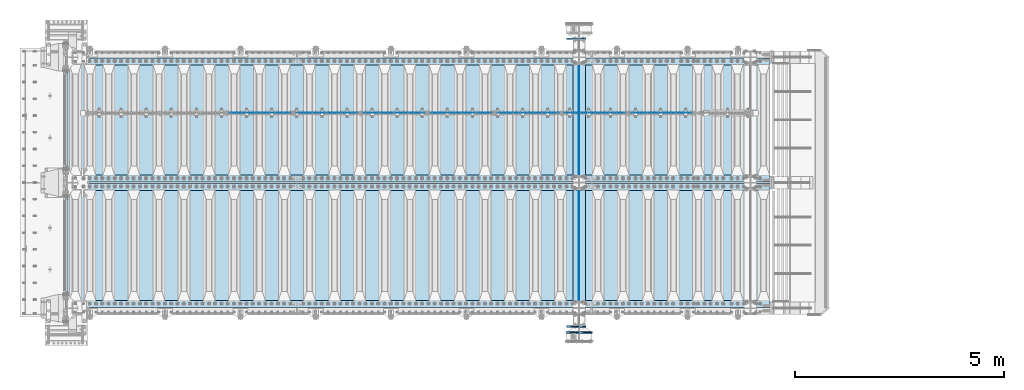
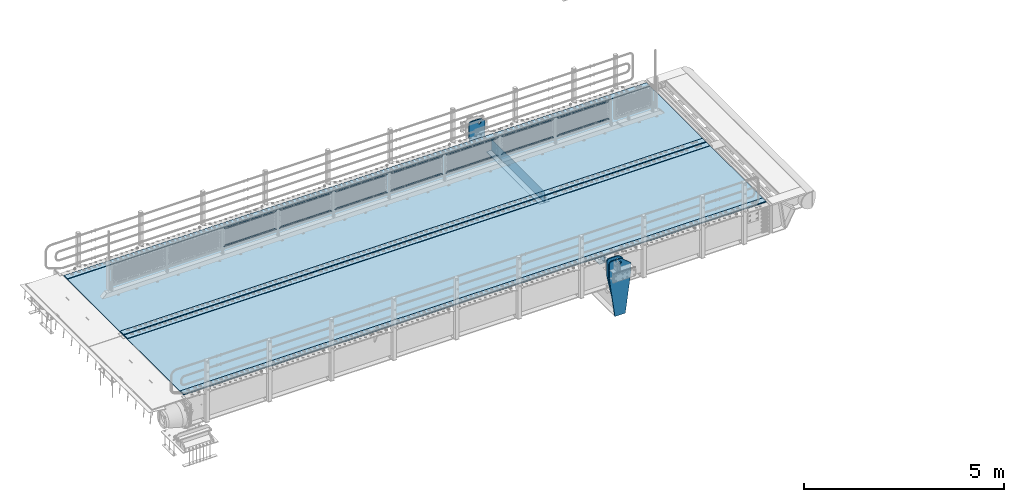
# One storey, part 164 of 208: 27 plates.
"""IFC2X3 building model written with IfcOpenShell, lengths in millimetres."""

from ifc_helpers import new_model, si_unit, frame, origin_with_axes, place, context, subcontext, project, spatial, faceted_brep, material, type_object, element, save


model = new_model("IFC2X3")

# Units and contexts
model_context = context("Model", 3, precision=1e-05, world=origin_with_axes())
body_context = subcontext(model_context, "Body", "Model", "MODEL_VIEW")
ifc_project = project(units=[si_unit("LENGTHUNIT", "METRE", prefix="MILLI"), si_unit("AREAUNIT", "SQUARE_METRE"), si_unit("VOLUMEUNIT", "CUBIC_METRE"), si_unit("MASSUNIT", "GRAM", prefix="KILO"), si_unit("TIMEUNIT", "SECOND"), si_unit("PLANEANGLEUNIT", "RADIAN"), si_unit("SOLIDANGLEUNIT", "STERADIAN"), si_unit("THERMODYNAMICTEMPERATUREUNIT", "DEGREE_CELSIUS"), si_unit("LUMINOUSINTENSITYUNIT", "LUMEN")], contexts=[model_context])

# Site, building, storey
site_placement = place(None, origin_with_axes())
site = spatial("IfcSite", under=ifc_project, at=site_placement, CompositionType="ELEMENT")
building_placement = place(site_placement, origin_with_axes())
building = spatial("IfcBuilding", under=site, at=building_placement, Name="Standard", CompositionType="ELEMENT")
storey_placement = place(building_placement, origin_with_axes())
storey = spatial("IfcBuildingStorey", under=building, at=storey_placement, Name="Undefined", CompositionType="ELEMENT", Elevation=0.0)

# Plates
ifc_material_1 = material(Name="STEEL/S355N")
plate_type_1 = type_object("IfcPlateType", PredefinedType="NOTDEFINED")
plate_1_placement = place(storey_placement, frame((-30040.0000000603, 6440.00000003457, -945.000018221991), z_axis=(-0.901283188008789, 0.0, 0.433230441004224), x_axis=(-0.433230441004229, 0.0, -0.901283188008786)))
element("IfcPlate", 1, at=plate_1_placement, inside=storey, type_object=plate_type_1, material=ifc_material_1, context=body_context, shape_type="Brep", body=[
    faceted_brep([(-929.368911797763, -15.0000000000009, 583.252555031781), (-929.368911797763, 14.9999999999991, 583.252555031781), (-937.30830201521, 14.9999999999991, 596.689503306556), (-937.30830201521, -15.0000000000009, 596.689503306556), (-939.501244651425, 14.9999999999991, 612.141897896337), (-939.501244651425, -15.0000000000009, 612.141897896337), (-935.613884069124, 14.9999999999991, 627.257251801122), (-935.613884069124, -15.0000000000009, 627.257251801122), (-926.238035677943, 14.9999999999991, 639.734389409947), (-926.238035677943, -15.0000000000009, 639.734389409947), (-912.801087403168, 14.9999999999991, 647.673779627392), (-912.801087403168, -15.0000000000009, 647.673779627392), (-897.348692813392, 14.9999999999991, 649.866722263607), (-897.348692813392, -15.0000000000009, 649.866722263607), (-882.233338908602, 14.9999999999991, 645.979361681304), (-882.233338908602, -15.0000000000009, 645.979361681304), (-869.756201299779, 14.9999999999991, 636.603513290123), (-869.756201299779, -15.0000000000009, 636.603513290123), (-861.816811082332, 14.9999999999991, 623.166565015352), (-861.816811082332, -15.0000000000009, 623.166565015352), (-859.623868446117, 14.9999999999991, 607.714170425574), (-859.623868446117, -15.0000000000009, 607.714170425574), (-863.51122902842, 14.9999999999991, 592.598816520785), (-863.51122902842, -15.0000000000009, 592.598816520785), (-872.887077419598, 14.9999999999991, 580.121678911964), (-872.887077419598, -15.0000000000009, 580.121678911964), (-886.324025694374, 14.9999999999991, 572.182288694516), (-886.324025694374, -15.0000000000009, 572.182288694516), (-901.77642028415, 14.9999999999991, 569.989346058297), (-901.77642028415, -15.0000000000009, 569.989346058297), (-916.89177418894, 14.9999999999991, 573.8767066406), (-916.89177418894, -15.0000000000009, 573.8767066406), (264.349946025897, -15.0, 42.1349881246279), (264.349946025897, 15.0, 42.1349881246279), (15.5957837766164, 14.9999999999991, 161.706590975653), (15.5957837766164, -15.0000000000009, 161.706590975653), (244.096420288088, -15.0, 1.4915713109076e-10), (244.096420288088, 15.0, 1.4915713109076e-10), (0.0, -15.0, 0.0), (0.0, 15.0, 0.0), (-976.801696777344, -15.0, 469.53082275391), (-976.801696777344, 15.0, 469.53082275391), (-1005.61097945758, -15.0, 584.572341407275), (-1005.61097945758, 15.0, 584.572341407275), (-1008.62086606961, -15.0, 603.379087420497), (-1008.62086606961, 15.0, 603.379087420497), (-1008.34154488137, -15.0, 622.423117789542), (-1008.34154488137, 15.0, 622.423117789542), (-1004.78138982927, -15.0, 641.133500175485), (-1004.78138982927, 15.0, 641.133500175485), (-998.047132923923, -15.0, 658.949304871177), (-998.047132923923, 15.0, 658.949304871177), (-903.392995239112, -15.0, 855.865677422371), (-903.392995239112, 15.0, 855.865677422371), (-891.965893301323, -15.0, 873.346258361024), (-891.965893301323, 15.0, 873.346258361024), (-876.403853384345, -15.0, 887.273651594045), (-876.403853384345, 15.0, 887.273651594045), (-857.767402657524, -15.0, 896.698728408126), (-857.767402657524, 15.0, 896.698728408126), (-837.326584279948, -15.0, 900.979185474858), (-837.326584279948, 15.0, 900.979185474858), (-816.474406068806, -15.0, 899.82331675561), (-816.474406068806, 15.0, 899.82331675561), (-796.631909330707, -15.0, 893.309892783491), (-796.631909330707, 15.0, 893.309892783491), (-427.105804443361, -15.0, 715.685424804691), (-427.105804443361, 15.0, 715.685424804691), (138.633743286133, -15.0, 288.410614013672), (138.633743286133, 15.0, 288.410614013672), (291.101928710939, -15.0, 97.7892227172888), (291.101928710939, 15.0, 97.7892227172888), (270.848403438671, -15.0, 55.6542355613128), (270.848403438671, 15.0, 55.6542355613128), (22.0942403916797, -15.0000000000009, 175.225838795785), (22.0942403916797, 14.9999999999991, 175.225838795785), (-855.850321891805, -15.0, 588.916357832572), (-852.143242433585, -15.0, 592.234043604338), (-847.175983303219, -15.0, 591.958700688101), (-843.858297531451, -15.0, 588.25162122988), (-844.13364044769, -15.0, 583.284362099515), (-847.840719905909, -15.0, 579.966676327746), (-852.807979036275, -15.0, 580.242019243986), (-856.125664808043, -15.0, 583.949098702204), (-844.13364044769, 15.0, 583.284362099515), (-847.840719905909, 15.0, 579.966676327746), (-843.858297531451, 15.0, 588.25162122988), (-847.175983303219, 15.0, 591.958700688101), (-852.143242433585, 15.0, 592.234043604338), (-855.850321891805, 15.0, 588.916357832572), (-856.125664808043, 15.0, 583.949098702204), (-852.807979036275, 15.0, 580.242019243986)], [[[0, 1, 2, 3]], [[3, 2, 4, 5]], [[5, 4, 6, 7]], [[7, 6, 8, 9]], [[9, 8, 10, 11]], [[11, 10, 12, 13]], [[13, 12, 14, 15]], [[15, 14, 16, 17]], [[17, 16, 18, 19]], [[19, 18, 20, 21]], [[21, 20, 22, 23]], [[23, 22, 24, 25]], [[25, 24, 26, 27]], [[27, 26, 28, 29]], [[29, 28, 30, 31]], [[31, 30, 1, 0]], [[32, 33, 34, 35]], [[36, 37, 33, 32]], [[36, 38, 39, 37]], [[38, 40, 41, 39]], [[40, 42, 43, 41]], [[42, 44, 45, 43]], [[44, 46, 47, 45]], [[46, 48, 49, 47]], [[48, 50, 51, 49]], [[50, 52, 53, 51]], [[52, 54, 55, 53]], [[54, 56, 57, 55]], [[56, 58, 59, 57]], [[58, 60, 61, 59]], [[60, 62, 63, 61]], [[62, 64, 65, 63]], [[64, 66, 67, 65]], [[66, 68, 69, 67]], [[68, 70, 71, 69]], [[71, 70, 72, 73]], [[74, 75, 73, 72]], [[35, 34, 75, 74]], [[72, 70, 68, 66, 64, 62, 60, 58, 56, 54, 52, 50, 48, 46, 44, 42, 40, 38, 36, 32, 35, 74], [3, 5, 7, 9, 11, 13, 15, 17, 19, 21, 23, 25, 27, 29, 31, 0], [76, 77, 78, 79, 80, 81, 82, 83]], [[80, 84, 85, 81]], [[79, 86, 84, 80]], [[78, 87, 86, 79]], [[77, 88, 87, 78]], [[76, 89, 88, 77]], [[83, 90, 89, 76]], [[82, 91, 90, 83]], [[81, 85, 91, 82]], [[37, 39, 41, 43, 45, 47, 49, 51, 53, 55, 57, 59, 61, 63, 65, 67, 69, 71, 73, 75, 34, 33], [26, 24, 22, 20, 18, 16, 14, 12, 10, 8, 6, 4, 2, 1, 30, 28], [84, 86, 87, 88, 89, 90, 91, 85]]]),
])
plate_2_placement = place(storey_placement, frame((-30039.9999999268, -440.00000003499, -945.000018229058), z_axis=(-0.901283188008789, 0.0, 0.433230441004224), x_axis=(-0.433230441004229, 0.0, -0.901283188008786)))
element("IfcPlate", 2, at=plate_2_placement, inside=storey, type_object=plate_type_1, material=ifc_material_1, context=body_context, shape_type="Brep", body=[
    faceted_brep([(22.0942403916797, -15.0000000000009, 175.225838795785), (22.0942403916797, 14.9999999999991, 175.225838795785), (270.848403438671, 15.0, 55.6542355613128), (270.848403438671, -15.0, 55.6542355613128), (15.5957837766164, -15.0000000000009, 161.706590975653), (15.5957837766164, 14.9999999999991, 161.706590975653), (264.349946025897, -15.0, 42.1349881246279), (264.349946025897, 15.0, 42.1349881246279), (244.096420288088, -15.0, 1.4915713109076e-10), (244.096420288088, 15.0, 1.4915713109076e-10), (0.0, -15.0, 0.0), (0.0, 15.0, 0.0), (-976.801818847653, -14.9999999999999, 469.530853271488), (-976.801818847654, 15.0000000000001, 469.530853271492), (-1005.61098604241, -15.0, 584.572481266794), (-1005.61098604242, 15.0, 584.572481266798), (-1008.62084772117, -15.0, 603.379189822339), (-1008.62084772117, 15.0, 603.379189822343), (-1008.341515547, -14.9999999999999, 622.423179098609), (-1008.341515547, 15.0000000000001, 622.423179098605), (-1004.78138982927, -15.0, 641.133500175485), (-1004.78138982927, 15.0, 641.133500175485), (-998.047132923923, -15.0, 658.949304871177), (-998.047132923923, 15.0, 658.949304871177), (-903.393050005918, -14.9999999999999, 855.865691431827), (-903.39305000592, 15.0000000000001, 855.865691431824), (-891.965949445443, -15.0, 873.346281101807), (-891.965949445441, 15.0, 873.346281101814), (-876.403907448017, -15.0, 887.273681839077), (-876.403907448019, 15.0, 887.273681839077), (-857.767451990487, -14.9999999999999, 896.698763823097), (-857.767451990487, 15.0000000000001, 896.6987638231), (-837.326627351591, -15.0, 900.979222969945), (-837.326627351591, 15.0, 900.979222969945), (-816.474442649627, -15.0, 899.82335291613), (-816.474442649629, 15.0, 899.82335291613), (-796.631940525467, -15.0, 893.309924335023), (-796.631940525469, 15.0, 893.309924335026), (-427.105804443356, -15.0, 715.685363769535), (-427.105804443354, 15.0, 715.685363769539), (138.633743286133, -15.0, 288.410614013672), (138.633743286133, 15.0, 288.410614013672), (291.101928710939, -15.0, 97.7892227172888), (291.101928710939, 15.0, 97.7892227172888), (-886.324025694374, -15.0000000000009, 572.182288694516), (-886.324025694374, 14.9999999999991, 572.182288694516), (-901.77642028415, 14.9999999999991, 569.989346058297), (-901.77642028415, -15.0000000000009, 569.989346058297), (-872.887077419598, -15.0000000000009, 580.121678911964), (-872.887077419598, 14.9999999999991, 580.121678911964), (-863.51122902842, -15.0000000000009, 592.598816520785), (-863.51122902842, 14.9999999999991, 592.598816520785), (-859.623868446117, -15.0000000000009, 607.714170425574), (-859.623868446117, 14.9999999999991, 607.714170425574), (-861.816811082332, -15.0000000000009, 623.166565015352), (-861.816811082332, 14.9999999999991, 623.166565015352), (-869.756201299779, -15.0000000000009, 636.603513290123), (-869.756201299779, 14.9999999999991, 636.603513290123), (-882.233338908602, -15.0000000000009, 645.979361681304), (-882.233338908602, 14.9999999999991, 645.979361681304), (-897.348692813392, -15.0000000000009, 649.866722263607), (-897.348692813392, 14.9999999999991, 649.866722263607), (-912.801087403168, -15.0000000000009, 647.673779627392), (-912.801087403168, 14.9999999999991, 647.673779627392), (-926.238035677943, -15.0000000000009, 639.734389409947), (-926.238035677943, 14.9999999999991, 639.734389409947), (-935.613884069124, -15.0000000000009, 627.257251801122), (-935.613884069124, 14.9999999999991, 627.257251801122), (-939.501244651425, -15.0000000000009, 612.141897896337), (-939.501244651425, 14.9999999999991, 612.141897896337), (-937.30830201521, -15.0000000000009, 596.689503306556), (-937.30830201521, 14.9999999999991, 596.689503306556), (-929.368911797763, -15.0000000000009, 583.252555031781), (-929.368911797763, 14.9999999999991, 583.252555031781), (-916.89177418894, -15.0000000000009, 573.8767066406), (-916.89177418894, 14.9999999999991, 573.8767066406), (-844.13364044769, 15.0, 583.284362099515), (-843.858297531451, 15.0, 588.25162122988), (-847.175983303219, 15.0, 591.958700688101), (-852.143242433585, 15.0, 592.234043604338), (-855.850321891805, 15.0, 588.916357832572), (-856.125664808043, 15.0, 583.949098702204), (-852.807979036275, 15.0, 580.242019243986), (-847.840719905909, 15.0, 579.966676327746), (-847.840719905909, -15.0, 579.966676327746), (-852.807979036275, -15.0, 580.242019243986), (-844.13364044769, -15.0, 583.284362099515), (-843.858297531451, -15.0, 588.25162122988), (-847.175983303219, -15.0, 591.958700688101), (-852.143242433585, -15.0, 592.234043604338), (-855.850321891805, -15.0, 588.916357832572), (-856.125664808043, -15.0, 583.949098702204)], [[[0, 1, 2, 3]], [[4, 5, 1, 0]], [[6, 7, 5, 4]], [[8, 9, 7, 6]], [[8, 10, 11, 9]], [[10, 12, 13, 11]], [[12, 14, 15, 13]], [[14, 16, 17, 15]], [[16, 18, 19, 17]], [[18, 20, 21, 19]], [[20, 22, 23, 21]], [[22, 24, 25, 23]], [[24, 26, 27, 25]], [[26, 28, 29, 27]], [[28, 30, 31, 29]], [[30, 32, 33, 31]], [[32, 34, 35, 33]], [[34, 36, 37, 35]], [[36, 38, 39, 37]], [[38, 40, 41, 39]], [[40, 42, 43, 41]], [[43, 42, 3, 2]], [[44, 45, 46, 47]], [[48, 49, 45, 44]], [[50, 51, 49, 48]], [[52, 53, 51, 50]], [[54, 55, 53, 52]], [[56, 57, 55, 54]], [[58, 59, 57, 56]], [[60, 61, 59, 58]], [[62, 63, 61, 60]], [[64, 65, 63, 62]], [[66, 67, 65, 64]], [[68, 69, 67, 66]], [[70, 71, 69, 68]], [[72, 73, 71, 70]], [[74, 75, 73, 72]], [[47, 46, 75, 74]], [[9, 11, 13, 15, 17, 19, 21, 23, 25, 27, 29, 31, 33, 35, 37, 39, 41, 43, 2, 1, 5, 7], [76, 77, 78, 79, 80, 81, 82, 83], [45, 49, 51, 53, 55, 57, 59, 61, 63, 65, 67, 69, 71, 73, 75, 46]], [[84, 83, 82, 85]], [[86, 76, 83, 84]], [[87, 77, 76, 86]], [[88, 78, 77, 87]], [[89, 79, 78, 88]], [[90, 80, 79, 89]], [[91, 81, 80, 90]], [[85, 82, 81, 91]], [[3, 42, 40, 38, 36, 34, 32, 30, 28, 26, 24, 22, 20, 18, 16, 14, 12, 10, 8, 6, 4, 0], [90, 89, 88, 87, 86, 84, 85, 91], [70, 68, 66, 64, 62, 60, 58, 56, 54, 52, 50, 48, 44, 47, 74, 72]]]),
])
plate_type_2 = type_object("IfcPlateType", PredefinedType="NOTDEFINED")
for number, where, z_axis, x_axis in (
    (3, (-30350.0, 3175.0, -343.0), (0.0, 1.0, 0.0), (1.0, 0.0, 0.0)),
    (4, (-30350.0, 175.0, -343.0), (0.0, 1.0, 0.0), (1.0, 0.0, 0.0)),
):
    element("IfcPlate", number, at=place(storey_placement, frame(where, z_axis=z_axis, x_axis=x_axis)), inside=storey, type_object=plate_type_2, material=ifc_material_1, context=body_context, shape_type="Brep", body=[
        faceted_brep([(0.0, -7.0, 0.0), (0.0, -7.0, 2650.0), (0.0, 7.0, 2650.0), (0.0, 7.0, 0.0), (300.0, -7.0, 2650.0), (300.0, 7.0, 2650.0), (300.0, -7.0, 0.0), (300.0, 7.0, 0.0)], [[[0, 1, 2, 3]], [[1, 4, 5, 2]], [[4, 6, 7, 5]], [[6, 0, 3, 7]], [[5, 7, 3, 2]], [[6, 4, 1, 0]]]),
    ])
plate_type_3 = type_object("IfcPlateType", PredefinedType="NOTDEFINED")
for number, where, z_axis, x_axis in (
    (5, (-30200.0, 5825.0, 0.0), (0.0, 0.0, -1.0), (0.0, -1.0, 0.0)),
    (6, (-30200.0, 2825.0, 0.0), (0.0, 0.0, -1.0), (0.0, -1.0, 0.0)),
):
    element("IfcPlate", number, at=place(storey_placement, frame(where, z_axis=z_axis, x_axis=x_axis)), inside=storey, type_object=plate_type_3, material=ifc_material_1, context=body_context, shape_type="Brep", body=[
        faceted_brep([(0.0, -5.0, 0.0), (0.0, -5.0, 336.0), (0.0, 5.0, 336.0), (0.0, 5.0, 0.0), (2650.0, -5.0, 336.0), (2650.0, 5.0, 336.0), (2650.0, -5.0, 0.0), (2650.0, 5.0, 0.0)], [[[0, 1, 2, 3]], [[1, 4, 5, 2]], [[4, 6, 7, 5]], [[6, 0, 3, 7]], [[5, 7, 3, 2]], [[6, 4, 1, 0]]]),
    ])
ifc_material_2 = material(Name="Misc_Undefined")
plate_type_4 = type_object("IfcPlateType", PredefinedType="NOTDEFINED")
plate_3_placement = place(storey_placement, frame((-28975.4949882696, 4670.5, 351.520303374641), z_axis=(0.0, 0.0, 1.0), x_axis=(1.0, 0.0, 0.0)))
element("IfcPlate", 7, at=plate_3_placement, inside=storey, type_object=plate_type_4, material=ifc_material_2, context=body_context, shape_type="Brep", body=[
    faceted_brep([(0.0, -1.49999999999909, 3.63797880709171e-12), (35.0002975463867, -1.5, 34.9996948242187), (35.0002975463867, 1.5, 34.9996948242187), (0.0, 1.50000000000182, 3.63797880709171e-12), (1457.99035644531, -1.5, 34.9999923706055), (1457.99035644531, 1.5, 34.9999923706055), (1492.98999023437, -1.5, -2.87985812974512e-09), (1492.98999023437, 1.5, -2.87985812974512e-09)], [[[0, 1, 2, 3]], [[1, 4, 5, 2]], [[4, 6, 7, 5]], [[6, 0, 3, 7]], [[5, 7, 3, 2]], [[6, 4, 1, 0]]]),
])
plate_4_placement = place(storey_placement, frame((-27482.4999998124, 4670.5, 914.520000175701), z_axis=(-0.707103624179499, 0.0, 0.707109938179501), x_axis=(-0.707109938179511, 0.0, -0.707103624179489)))
element("IfcPlate", 8, at=plate_4_placement, inside=storey, type_object=plate_type_4, material=ifc_material_2, context=body_context, shape_type="Brep", body=[
    faceted_brep([(0.0, -1.49999999999909, 3.63797880709171e-12), (1055.71520996092, -1.5, 1055.70581054688), (1055.71520996092, 1.5, 1055.70581054688), (0.0, 1.50000000000182, 3.63797880709171e-12), (1055.7081298828, -1.5, 1006.20135498047), (1055.7081298828, 1.5, 1006.20135498047), (49.4976959228516, -1.5, 6.91215973347425e-11), (49.4976959228516, 1.5, 6.91215973347425e-11)], [[[0, 1, 2, 3]], [[1, 4, 5, 2]], [[4, 6, 7, 5]], [[6, 0, 3, 7]], [[5, 7, 3, 2]], [[6, 4, 1, 0]]]),
])
plate_5_placement = place(storey_placement, frame((-30575.4949882696, 4670.5, 351.520303374641), z_axis=(0.0, 0.0, 1.0), x_axis=(1.0, 0.0, 0.0)))
element("IfcPlate", 9, at=plate_5_placement, inside=storey, type_object=plate_type_4, material=ifc_material_2, context=body_context, shape_type="Brep", body=[
    faceted_brep([(0.0, -1.49999999999909, 3.63797880709171e-12), (35.0002975463867, -1.5, 34.9996948242187), (35.0002975463867, 1.5, 34.9996948242187), (0.0, 1.50000000000182, 3.63797880709171e-12), (1457.99035644531, -1.5, 34.9999923706055), (1457.99035644531, 1.5, 34.9999923706055), (1492.98999023437, -1.5, -2.87985812974512e-09), (1492.98999023437, 1.5, -2.87985812974512e-09)], [[[0, 1, 2, 3]], [[1, 4, 5, 2]], [[4, 6, 7, 5]], [[6, 0, 3, 7]], [[5, 7, 3, 2]], [[6, 4, 1, 0]]]),
])
plate_6_placement = place(storey_placement, frame((-29082.4999998124, 4670.5, 914.520000175701), z_axis=(-0.707103624179499, 0.0, 0.707109938179501), x_axis=(-0.707109938179511, 0.0, -0.707103624179489)))
element("IfcPlate", 10, at=plate_6_placement, inside=storey, type_object=plate_type_4, material=ifc_material_2, context=body_context, shape_type="Brep", body=[
    faceted_brep([(0.0, -1.49999999999909, 3.63797880709171e-12), (1055.71520996092, -1.5, 1055.70581054688), (1055.71520996092, 1.5, 1055.70581054688), (0.0, 1.50000000000182, 3.63797880709171e-12), (1055.7081298828, -1.5, 1006.20135498047), (1055.7081298828, 1.5, 1006.20135498047), (49.4976959228516, -1.5, 6.91215973347425e-11), (49.4976959228516, 1.5, 6.91215973347425e-11)], [[[0, 1, 2, 3]], [[1, 4, 5, 2]], [[4, 6, 7, 5]], [[6, 0, 3, 7]], [[5, 7, 3, 2]], [[6, 4, 1, 0]]]),
])
plate_7_placement = place(storey_placement, frame((-32175.4949882696, 4670.5, 351.520303374641), z_axis=(0.0, 0.0, 1.0), x_axis=(1.0, 0.0, 0.0)))
element("IfcPlate", 11, at=plate_7_placement, inside=storey, type_object=plate_type_4, material=ifc_material_2, context=body_context, shape_type="Brep", body=[
    faceted_brep([(0.0, -1.49999999999909, 3.63797880709171e-12), (35.0002975463867, -1.5, 34.9996948242187), (35.0002975463867, 1.5, 34.9996948242187), (0.0, 1.50000000000182, 3.63797880709171e-12), (1457.99035644531, -1.5, 34.9999923706055), (1457.99035644531, 1.5, 34.9999923706055), (1492.98999023437, -1.5, -2.87985812974512e-09), (1492.98999023437, 1.5, -2.87985812974512e-09)], [[[0, 1, 2, 3]], [[1, 4, 5, 2]], [[4, 6, 7, 5]], [[6, 0, 3, 7]], [[5, 7, 3, 2]], [[6, 4, 1, 0]]]),
])
plate_8_placement = place(storey_placement, frame((-30682.4999998124, 4670.5, 914.520000175701), z_axis=(-0.707103624179499, 0.0, 0.707109938179501), x_axis=(-0.707109938179511, 0.0, -0.707103624179489)))
element("IfcPlate", 12, at=plate_8_placement, inside=storey, type_object=plate_type_4, material=ifc_material_2, context=body_context, shape_type="Brep", body=[
    faceted_brep([(0.0, -1.49999999999909, 3.63797880709171e-12), (1055.71520996092, -1.5, 1055.70581054688), (1055.71520996092, 1.5, 1055.70581054688), (0.0, 1.50000000000182, 3.63797880709171e-12), (1055.7081298828, -1.5, 1006.20135498047), (1055.7081298828, 1.5, 1006.20135498047), (49.4976959228516, -1.5, 6.91215973347425e-11), (49.4976959228516, 1.5, 6.91215973347425e-11)], [[[0, 1, 2, 3]], [[1, 4, 5, 2]], [[4, 6, 7, 5]], [[6, 0, 3, 7]], [[5, 7, 3, 2]], [[6, 4, 1, 0]]]),
])
plate_9_placement = place(storey_placement, frame((-33775.4949882696, 4670.5, 351.520303374641), z_axis=(0.0, 0.0, 1.0), x_axis=(1.0, 0.0, 0.0)))
element("IfcPlate", 13, at=plate_9_placement, inside=storey, type_object=plate_type_4, material=ifc_material_2, context=body_context, shape_type="Brep", body=[
    faceted_brep([(0.0, -1.49999999999909, 3.63797880709171e-12), (35.0002975463867, -1.5, 34.9996948242187), (35.0002975463867, 1.5, 34.9996948242187), (0.0, 1.50000000000182, 3.63797880709171e-12), (1457.99035644531, -1.5, 34.9999923706055), (1457.99035644531, 1.5, 34.9999923706055), (1492.98999023437, -1.5, -2.87985812974512e-09), (1492.98999023437, 1.5, -2.87985812974512e-09)], [[[0, 1, 2, 3]], [[1, 4, 5, 2]], [[4, 6, 7, 5]], [[6, 0, 3, 7]], [[5, 7, 3, 2]], [[6, 4, 1, 0]]]),
])
plate_10_placement = place(storey_placement, frame((-32282.4999998124, 4670.5, 914.520000175701), z_axis=(-0.707103624179499, 0.0, 0.707109938179501), x_axis=(-0.707109938179511, 0.0, -0.707103624179489)))
element("IfcPlate", 14, at=plate_10_placement, inside=storey, type_object=plate_type_4, material=ifc_material_2, context=body_context, shape_type="Brep", body=[
    faceted_brep([(0.0, -1.49999999999909, 3.63797880709171e-12), (1055.71520996092, -1.5, 1055.70581054688), (1055.71520996092, 1.5, 1055.70581054688), (0.0, 1.50000000000182, 3.63797880709171e-12), (1055.7081298828, -1.5, 1006.20135498047), (1055.7081298828, 1.5, 1006.20135498047), (49.4976959228516, -1.5, 6.91215973347425e-11), (49.4976959228516, 1.5, 6.91215973347425e-11)], [[[0, 1, 2, 3]], [[1, 4, 5, 2]], [[4, 6, 7, 5]], [[6, 0, 3, 7]], [[5, 7, 3, 2]], [[6, 4, 1, 0]]]),
])
plate_11_placement = place(storey_placement, frame((-35375.4949882696, 4670.5, 351.520303374641), z_axis=(0.0, 0.0, 1.0), x_axis=(1.0, 0.0, 0.0)))
element("IfcPlate", 15, at=plate_11_placement, inside=storey, type_object=plate_type_4, material=ifc_material_2, context=body_context, shape_type="Brep", body=[
    faceted_brep([(0.0, -1.49999999999909, 3.63797880709171e-12), (35.0002975463867, -1.5, 34.9996948242187), (35.0002975463867, 1.5, 34.9996948242187), (0.0, 1.50000000000182, 3.63797880709171e-12), (1457.99035644531, -1.5, 34.9999923706055), (1457.99035644531, 1.5, 34.9999923706055), (1492.98999023437, -1.5, -2.87985812974512e-09), (1492.98999023437, 1.5, -2.87985812974512e-09)], [[[0, 1, 2, 3]], [[1, 4, 5, 2]], [[4, 6, 7, 5]], [[6, 0, 3, 7]], [[5, 7, 3, 2]], [[6, 4, 1, 0]]]),
])
plate_12_placement = place(storey_placement, frame((-33882.4999998124, 4670.5, 914.520000175701), z_axis=(-0.707103624179499, 0.0, 0.707109938179501), x_axis=(-0.707109938179511, 0.0, -0.707103624179489)))
element("IfcPlate", 16, at=plate_12_placement, inside=storey, type_object=plate_type_4, material=ifc_material_2, context=body_context, shape_type="Brep", body=[
    faceted_brep([(0.0, -1.49999999999909, 3.63797880709171e-12), (1055.71520996092, -1.5, 1055.70581054688), (1055.71520996092, 1.5, 1055.70581054688), (0.0, 1.50000000000182, 3.63797880709171e-12), (1055.7081298828, -1.5, 1006.20135498047), (1055.7081298828, 1.5, 1006.20135498047), (49.4976959228516, -1.5, 6.91215973347425e-11), (49.4976959228516, 1.5, 6.91215973347425e-11)], [[[0, 1, 2, 3]], [[1, 4, 5, 2]], [[4, 6, 7, 5]], [[6, 0, 3, 7]], [[5, 7, 3, 2]], [[6, 4, 1, 0]]]),
])
plate_13_placement = place(storey_placement, frame((-36975.4949882696, 4670.5, 351.520303374641), z_axis=(0.0, 0.0, 1.0), x_axis=(1.0, 0.0, 0.0)))
element("IfcPlate", 17, at=plate_13_placement, inside=storey, type_object=plate_type_4, material=ifc_material_2, context=body_context, shape_type="Brep", body=[
    faceted_brep([(0.0, -1.49999999999909, 3.63797880709171e-12), (35.0002975463867, -1.5, 34.9996948242187), (35.0002975463867, 1.5, 34.9996948242187), (0.0, 1.50000000000182, 3.63797880709171e-12), (1457.99035644531, -1.5, 34.9999923706055), (1457.99035644531, 1.5, 34.9999923706055), (1492.98999023437, -1.5, -2.87985812974512e-09), (1492.98999023437, 1.5, -2.87985812974512e-09)], [[[0, 1, 2, 3]], [[1, 4, 5, 2]], [[4, 6, 7, 5]], [[6, 0, 3, 7]], [[5, 7, 3, 2]], [[6, 4, 1, 0]]]),
])
plate_14_placement = place(storey_placement, frame((-35482.4999998124, 4670.5, 914.520000175701), z_axis=(-0.707103624179499, 0.0, 0.707109938179501), x_axis=(-0.707109938179511, 0.0, -0.707103624179489)))
element("IfcPlate", 18, at=plate_14_placement, inside=storey, type_object=plate_type_4, material=ifc_material_2, context=body_context, shape_type="Brep", body=[
    faceted_brep([(0.0, -1.49999999999909, 3.63797880709171e-12), (1055.71520996092, -1.5, 1055.70581054688), (1055.71520996092, 1.5, 1055.70581054688), (0.0, 1.50000000000182, 3.63797880709171e-12), (1055.7081298828, -1.5, 1006.20135498047), (1055.7081298828, 1.5, 1006.20135498047), (49.4976959228516, -1.5, 6.91215973347425e-11), (49.4976959228516, 1.5, 6.91215973347425e-11)], [[[0, 1, 2, 3]], [[1, 4, 5, 2]], [[4, 6, 7, 5]], [[6, 0, 3, 7]], [[5, 7, 3, 2]], [[6, 4, 1, 0]]]),
])
plate_15_placement = place(storey_placement, frame((-38575.4949882696, 4670.5, 351.520303374641), z_axis=(0.0, 0.0, 1.0), x_axis=(1.0, 0.0, 0.0)))
element("IfcPlate", 19, at=plate_15_placement, inside=storey, type_object=plate_type_4, material=ifc_material_2, context=body_context, shape_type="Brep", body=[
    faceted_brep([(0.0, -1.49999999999909, 3.63797880709171e-12), (35.0002975463867, -1.5, 34.9996948242187), (35.0002975463867, 1.5, 34.9996948242187), (0.0, 1.50000000000182, 3.63797880709171e-12), (1457.99035644531, -1.5, 34.9999923706055), (1457.99035644531, 1.5, 34.9999923706055), (1492.98999023437, -1.5, -2.87985812974512e-09), (1492.98999023437, 1.5, -2.87985812974512e-09)], [[[0, 1, 2, 3]], [[1, 4, 5, 2]], [[4, 6, 7, 5]], [[6, 0, 3, 7]], [[5, 7, 3, 2]], [[6, 4, 1, 0]]]),
])
plate_16_placement = place(storey_placement, frame((-37082.4999998124, 4670.5, 914.520000175701), z_axis=(-0.707103624179499, 0.0, 0.707109938179501), x_axis=(-0.707109938179511, 0.0, -0.707103624179489)))
element("IfcPlate", 20, at=plate_16_placement, inside=storey, type_object=plate_type_4, material=ifc_material_2, context=body_context, shape_type="Brep", body=[
    faceted_brep([(0.0, -1.49999999999909, 3.63797880709171e-12), (1055.71520996092, -1.5, 1055.70581054688), (1055.71520996092, 1.5, 1055.70581054688), (0.0, 1.50000000000182, 3.63797880709171e-12), (1055.7081298828, -1.5, 1006.20135498047), (1055.7081298828, 1.5, 1006.20135498047), (49.4976959228516, -1.5, 6.91215973347425e-11), (49.4976959228516, 1.5, 6.91215973347425e-11)], [[[0, 1, 2, 3]], [[1, 4, 5, 2]], [[4, 6, 7, 5]], [[6, 0, 3, 7]], [[5, 7, 3, 2]], [[6, 4, 1, 0]]]),
])
plate_type_5 = type_object("IfcPlateType", PredefinedType="NOTDEFINED")
plate_17_placement = place(storey_placement, frame((-30049.9999999403, -580.000000034991, -1470.00001822256), z_axis=(0.0, 0.0, 1.0), x_axis=(-1.0, 0.0, 0.0)))
element("IfcPlate", 21, at=plate_17_placement, inside=storey, type_object=plate_type_5, material=ifc_material_1, context=body_context, shape_type="Brep", body=[
    faceted_brep([(145.403805922699, -14.9999999999999, 1549.59619407771), (145.403805922699, 15.0, 1549.59619407771), (150.000000000411, 15.0, 1551.5), (150.000000000411, -14.9999999999999, 1551.5), (154.596194078124, 15.0, 1549.59619407771), (154.596194078124, -14.9999999999999, 1549.59619407771), (156.500000000411, 15.0, 1545.0), (156.500000000411, -14.9999999999999, 1545.0), (154.596194078124, 15.0, 1540.40380592229), (154.596194078124, -14.9999999999999, 1540.40380592229), (150.000000000411, 15.0, 1538.5), (150.000000000411, -14.9999999999999, 1538.5), (145.403805922699, 15.0, 1540.40380592229), (145.403805922699, -14.9999999999999, 1540.40380592229), (143.500000000411, 15.0, 1545.0), (143.500000000411, -14.9999999999999, 1545.0), (300.0, -15.0, 0.0), (0.0, -15.0, 0.0), (0.0, 15.0, 0.0), (300.0, 15.0, 0.0), (462.5, -15.0, 1210.0), (462.5, 15.0, 1210.0), (462.5, -15.0, 1630.0), (462.5, 15.0, 1630.0), (459.774066103124, -15.0, 1650.7055236082), (459.774066103124, 15.0, 1650.7055236082), (451.782032302755, -15.0, 1670.0), (451.782032302755, 15.0, 1670.0), (439.068542494922, -15.0, 1686.56854249492), (439.068542494922, 15.0, 1686.56854249492), (422.5, -15.0, 1699.28203230276), (422.5, 15.0, 1699.28203230276), (403.205523608201, -15.0, 1707.27406610313), (403.205523608201, 15.0, 1707.27406610313), (382.5, -15.0, 1710.0), (382.5, 15.0, 1710.0), (151.788081037081, -15.0, 1710.0), (151.788081037081, 15.0, 1710.0), (132.694887325029, -15.0, 1708.33028179541), (132.694887325029, 15.0, 1708.33028179541), (114.181334578883, -15.0, 1703.37181734316), (114.181334578883, 15.0, 1703.37181734316), (96.809466726856, -15.0, 1695.27513824985), (96.809466726856, 15.0, 1695.27513824985), (81.1066678416755, -15.0, 1684.28604765144), (81.1066678416755, 15.0, 1684.28604765144), (-162.5, -15.0, 1480.0), (-162.5, 15.0, 1480.0), (-162.5, -15.0, 1210.0), (-162.5, 15.0, 1210.0), (121.715728752948, -15.0, 1628.28427124746), (134.692662705809, -15.0, 1636.95518130045), (150.000000000411, -15.0, 1640.0), (165.307337295013, -15.0, 1636.95518130045), (178.284271247874, -15.0, 1628.28427124746), (186.955181300862, -15.0, 1615.3073372946), (190.000000000411, -15.0, 1600.0), (186.955181300862, -15.0, 1584.6926627054), (178.284271247874, -15.0, 1571.71572875254), (165.307337295013, -15.0, 1563.04481869955), (150.000000000411, -15.0, 1560.0), (134.692662705809, -15.0, 1563.04481869955), (121.715728752948, -15.0, 1571.71572875254), (113.04481869996, -15.0, 1584.6926627054), (110.000000000411, -15.0, 1600.0), (113.04481869996, -15.0, 1615.3073372946), (121.715728752948, 14.999999999953, 1571.71572875254), (113.04481869996, 14.999999999953, 1584.6926627054), (134.692662705809, 14.999999999953, 1563.04481869955), (150.000000000411, 14.999999999953, 1560.0), (165.307337295013, 14.999999999953, 1563.04481869955), (178.284271247874, 14.999999999953, 1571.71572875254), (186.955181300862, 14.999999999953, 1584.6926627054), (190.000000000411, 14.999999999953, 1600.0), (186.955181300862, 14.999999999953, 1615.3073372946), (178.284271247874, 14.999999999953, 1628.28427124746), (165.307337295013, 14.999999999953, 1636.95518130045), (150.000000000411, 14.999999999953, 1640.0), (134.692662705809, 14.999999999953, 1636.95518130045), (121.715728752948, 14.999999999953, 1628.28427124746), (113.04481869996, 14.999999999953, 1615.3073372946), (110.000000000411, 14.999999999953, 1600.0)], [[[0, 1, 2, 3]], [[3, 2, 4, 5]], [[5, 4, 6, 7]], [[7, 6, 8, 9]], [[9, 8, 10, 11]], [[11, 10, 12, 13]], [[13, 12, 14, 15]], [[15, 14, 1, 0]], [[16, 17, 18, 19]], [[20, 16, 19, 21]], [[22, 20, 21, 23]], [[24, 22, 23, 25]], [[26, 24, 25, 27]], [[28, 26, 27, 29]], [[30, 28, 29, 31]], [[32, 30, 31, 33]], [[34, 32, 33, 35]], [[36, 34, 35, 37]], [[38, 36, 37, 39]], [[40, 38, 39, 41]], [[42, 40, 41, 43]], [[44, 42, 43, 45]], [[46, 44, 45, 47]], [[48, 46, 47, 49]], [[17, 48, 49, 18]], [[16, 20, 22, 24, 26, 28, 30, 32, 34, 36, 38, 40, 42, 44, 46, 48, 17], [3, 5, 7, 9, 11, 13, 15, 0], [50, 51, 52, 53, 54, 55, 56, 57, 58, 59, 60, 61, 62, 63, 64, 65]], [[62, 66, 67, 63]], [[61, 68, 66, 62]], [[60, 69, 68, 61]], [[59, 70, 69, 60]], [[58, 71, 70, 59]], [[57, 72, 71, 58]], [[56, 73, 72, 57]], [[55, 74, 73, 56]], [[54, 75, 74, 55]], [[53, 76, 75, 54]], [[52, 77, 76, 53]], [[51, 78, 77, 52]], [[50, 79, 78, 51]], [[65, 80, 79, 50]], [[64, 81, 80, 65]], [[63, 67, 81, 64]], [[47, 45, 43, 41, 39, 37, 35, 33, 31, 29, 27, 25, 23, 21, 19, 18, 49], [10, 8, 6, 4, 2, 1, 14, 12], [66, 68, 69, 70, 71, 72, 73, 74, 75, 76, 77, 78, 79, 80, 81, 67]]]),
])
ifc_material_3 = material(Name="STEEL/S235JR")
plate_type_6 = type_object("IfcPlateType", PredefinedType="NOTDEFINED")
for number, where, z_axis, x_axis in (
    (22, (-25643.0, 5815.0, 20.0), (-1.0, 0.0, 0.0), (0.0, 1.0, 0.0)),
    (23, (-25643.0, 3015.0, 20.0), (-1.0, 0.0, 0.0), (0.0, 1.0, 0.0)),
    (24, (-25643.0, 2815.0, 20.0), (-1.0, 0.0, 0.0), (0.0, 1.0, 0.0)),
    (25, (-25643.0, 15.0, 20.0), (-1.0, 0.0, 0.0), (0.0, 1.0, 0.0)),
):
    element("IfcPlate", number, at=place(storey_placement, frame(where, z_axis=z_axis, x_axis=x_axis)), inside=storey, type_object=plate_type_6, material=ifc_material_3, context=body_context, shape_type="Brep", body=[
        faceted_brep([(0.0, -6.0, 0.0), (0.0, -6.0, 16787.0), (0.0, 6.0, 16787.0), (0.0, 6.0, 0.0), (170.0, -6.0, 16787.0), (170.0, 6.0, 16787.0), (170.0, -6.0, 0.0), (170.0, 6.0, 0.0)], [[[0, 1, 2, 3]], [[1, 4, 5, 2]], [[4, 6, 7, 5]], [[6, 0, 3, 7]], [[5, 7, 3, 2]], [[6, 4, 1, 0]]]),
    ])
plate_type_7 = type_object("IfcPlateType", PredefinedType="NOTDEFINED")
for number, where, z_axis, x_axis in (
    (26, (-42440.0, 5995.0, 7.0), (1.0, 0.0, 0.0), (0.0, -1.0, 0.0)),
    (27, (-42440.0, 2995.0, 7.0), (1.0, 0.0, 0.0), (0.0, -1.0, 0.0)),
):
    element("IfcPlate", number, at=place(storey_placement, frame(where, z_axis=z_axis, x_axis=x_axis)), inside=storey, type_object=plate_type_7, material=ifc_material_1, context=body_context, shape_type="Brep", body=[
        faceted_brep([(0.0, -7.0, 0.0), (-2.96859070658684e-09, -7.0, 16807.0), (-2.96859070658684e-09, 7.0, 16807.0), (0.0, 7.0, 0.0), (2990.0, -7.0, 16807.0), (2990.0, 7.0, 16807.0), (2990.0, -7.0, 0.0), (2990.0, 7.0, 0.0)], [[[0, 1, 2, 3]], [[1, 4, 5, 2]], [[4, 6, 7, 5]], [[6, 0, 3, 7]], [[5, 7, 3, 2]], [[6, 4, 1, 0]]]),
    ])

save(model, "model.ifc")
